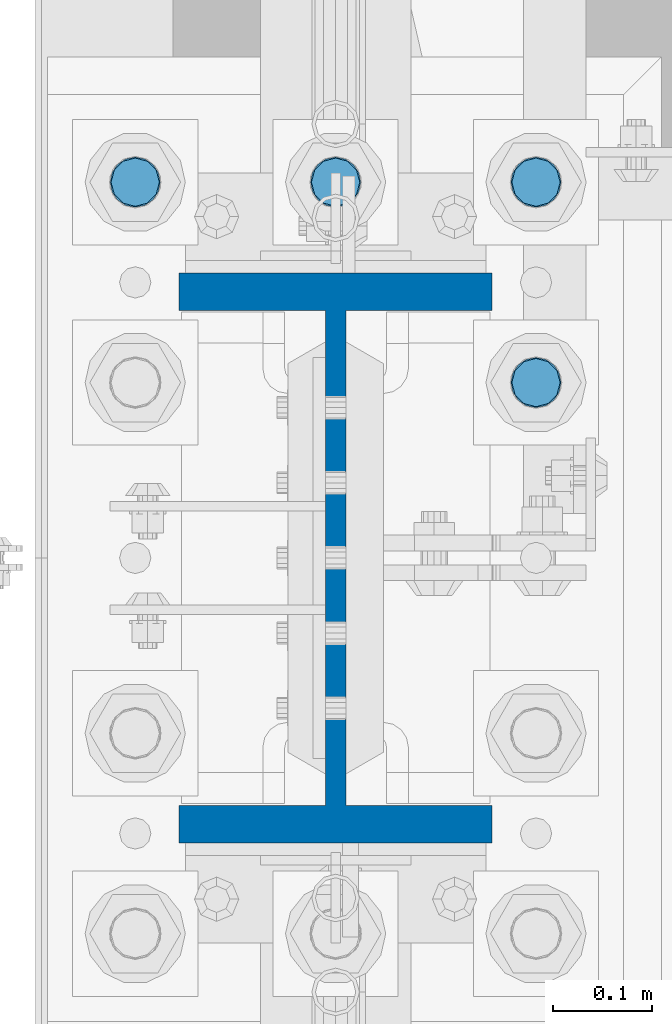
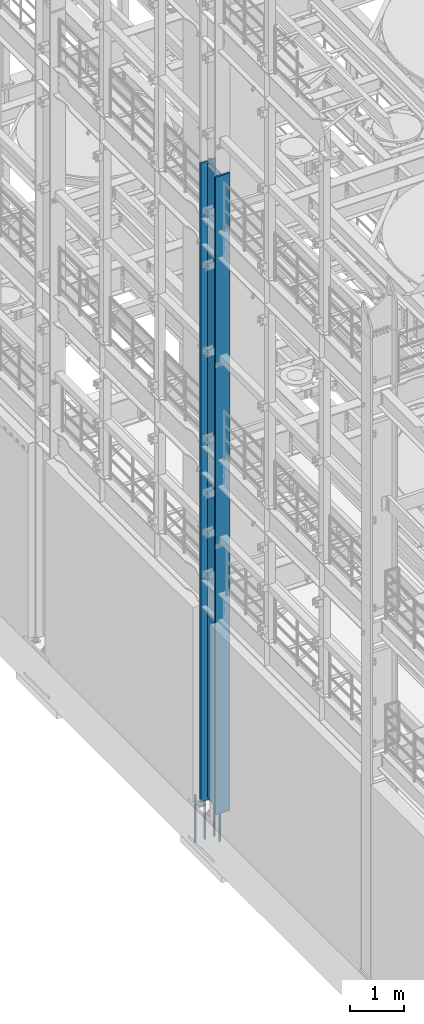
# One storey, part 688 of 1876: 5 columns, 2 elements without a shape of their own.
"""IFC2X3 building model written with IfcOpenShell, lengths in millimetres."""

from ifc_helpers import new_model, si_unit, frame, origin_with_axes, place, context, subcontext, project, spatial, faceted_brep, material, type_object, element, aggregate, save


model = new_model("IFC2X3")

# Units and contexts
model_context = context("Model", 3, precision=1e-05, world=origin_with_axes())
body_context = subcontext(model_context, "Body", "Model", "MODEL_VIEW")
ifc_project = project(units=[si_unit("LENGTHUNIT", "METRE", prefix="MILLI"), si_unit("AREAUNIT", "SQUARE_METRE"), si_unit("VOLUMEUNIT", "CUBIC_METRE"), si_unit("MASSUNIT", "GRAM", prefix="KILO"), si_unit("TIMEUNIT", "SECOND"), si_unit("PLANEANGLEUNIT", "RADIAN"), si_unit("SOLIDANGLEUNIT", "STERADIAN"), si_unit("THERMODYNAMICTEMPERATUREUNIT", "DEGREE_CELSIUS"), si_unit("LUMINOUSINTENSITYUNIT", "LUMEN")], contexts=[model_context])

# Site, building, storey
site_placement = place(None, origin_with_axes())
site = spatial("IfcSite", under=ifc_project, at=site_placement, CompositionType="ELEMENT")
building_placement = place(site_placement, origin_with_axes())
building = spatial("IfcBuilding", under=site, at=building_placement, Name="Undefined", CompositionType="ELEMENT")
storey_placement = place(building_placement, origin_with_axes())
storey = spatial("IfcBuildingStorey", under=building, at=storey_placement, Name="Undefined", CompositionType="ELEMENT", Elevation=0.0)

# Assembly, column
assembly_1_placement = place(storey_placement, origin_with_axes())
assembly_1 = element("IfcElementAssembly", 1, at=assembly_1_placement, inside=storey, Name="COLUMN", AssemblyPlace="NOTDEFINED", PredefinedType="RIGID_FRAME")
ifc_material_1 = material(Name="STEEL/A992")
column_type_1 = type_object("IfcColumnType", Name="W21X182", PredefinedType="NOTDEFINED")
column_1_placement = place(assembly_1_placement, frame((0.0, 1524.0, 0.0), z_axis=(0.0, 1.0, 0.0), x_axis=(0.0, 0.0, 1.0)))
column_1 = element("IfcColumn", 2, at=column_1_placement, type_object=column_type_1, material=ifc_material_1, Name="COLUMN", ObjectType="W21X182", context=body_context, shape_type="Brep", body=[
    faceted_brep([(115.887500412823, -10.3187499999967, 200.025000762939), (95.25, 10.31875, 200.025000762939), (95.25, 10.31875, -200.025000762939), (115.887500412823, -10.31875, -200.025000762939), (14528.8, -158.75, 288.925), (14528.8, 158.75, 288.925), (133.350000412822, 158.75, 288.925), (133.350000412824, -158.75, 288.925), (146.050000412824, -158.75, 250.825), (14478.0, -158.75, 250.825), (14528.8, -158.75, 250.825), (95.25, -158.75, 250.825), (146.050000412823, -10.3187500000004, 250.825), (14478.0, -10.3187500000004, 250.825), (14528.8, -10.3187500000004, 250.825), (95.25, -10.3187500000004, 250.825), (14528.8, -158.75, -288.925), (14528.8, -158.75, -250.825), (14478.0000007629, -158.75, -250.825), (146.050000412824, -158.75, -250.825), (95.25, -158.75, -250.825), (133.350000412824, -158.75, -288.925), (14528.8, 158.75, -288.925), (133.350000412822, 158.75, -288.925), (146.050000412824, 158.75, -250.825), (14478.0000007629, 158.75, -250.825), (14528.8, 158.75, -250.825), (95.25, 158.75, -250.825), (14528.8, 10.3187500000004, -250.825), (14528.8, -10.3187500000004, -250.825), (14478.0000007629, -10.3187500000004, -250.825), (146.050000412824, -10.3187500000004, -250.825), (95.25, -10.3187500000004, -250.825), (120.650000794293, -10.3187500000004, -200.025000762939), (120.650000794293, 10.3187500000004, -200.025000762939), (130.370159830384, 10.3187500000004, -201.958460608115), (130.370159830384, -10.3187500000004, -201.958460608115), (138.610512766692, 10.3187500000004, -207.464488409071), (138.610512766692, -10.3187500000004, -207.464488409071), (144.116540567648, 10.3187500000004, -215.704841345378), (144.116540567648, -10.3187500000004, -215.704841345378), (146.050000412823, 10.3187500000004, -225.42500038147), (146.050000412823, -10.3187500000004, -225.42500038147), (146.050000412824, 10.3187500000004, -250.825), (95.25, 10.3187500000004, -250.825), (14478.0000007629, 10.3187500000004, -250.825), (14481.8669204533, 10.3187500000004, -231.384681927818), (14481.8669204533, -10.3187500000004, -231.384681927818), (14492.8789760552, 10.3187500000004, -214.903976055203), (14492.8789760552, -10.3187500000004, -214.903976055203), (14509.3596819278, 10.3187500000004, -203.891920453291), (14509.3596819278, -10.3187500000004, -203.891920453291), (14528.8, -10.3187500000004, -200.025000762939), (14528.8, 10.3187500000004, -200.025000762939), (14528.8, 10.3187500000004, 200.025000762939), (14528.8, -10.3187500000004, 200.025000762939), (14509.3596811649, 10.3187500000004, 203.891920453291), (14509.3596811649, -10.3187500000004, 203.891920453291), (14492.8789752923, 10.3187500000004, 214.903976055203), (14492.8789752923, -10.3187500000004, 214.903976055203), (14481.8669196904, 10.3187500000004, 231.384681927818), (14481.8669196904, -10.3187500000004, 231.384681927818), (14478.0, 10.3187500000004, 250.825), (14528.8, 10.3187500000004, 250.825), (14528.8, 158.75, 250.825), (14478.0, 158.75, 250.825), (146.050000412824, 158.75, 250.825), (95.25, 158.75, 250.825), (95.25, 10.3187500000004, 250.825), (146.050000412824, 10.3187500000004, 250.825), (146.050000412823, 10.3187500000004, 225.42500038147), (146.050000412823, -10.3187500000004, 225.42500038147), (144.116540567648, 10.3187500000004, 215.704841345378), (144.116540567648, -10.3187500000004, 215.704841345378), (138.610512766692, 10.3187500000004, 207.464488409071), (138.610512766692, -10.3187500000004, 207.464488409071), (130.370159830384, 10.3187500000004, 201.958460608115), (130.370159830384, -10.3187500000004, 201.958460608115), (120.650000794293, 10.3187500000004, 200.025000762939), (120.650000794293, -10.3187500000004, 200.025000762939)], [[[0, 1, 2, 3]], [[4, 5, 6, 7]], [[8, 9, 10, 4, 7, 11]], [[12, 13, 14, 10, 9, 8, 11, 15]], [[16, 17, 18, 19, 20, 21]], [[22, 16, 21, 23]], [[24, 25, 26, 22, 23, 27]], [[17, 16, 22, 26, 28, 29]], [[19, 18, 17, 29, 30, 31, 32, 20]], [[33, 34, 35, 36]], [[36, 35, 37, 38]], [[38, 37, 39, 40]], [[40, 39, 41, 42]], [[42, 41, 43, 31]], [[31, 43, 44, 32]], [[27, 23, 21, 20, 32, 44]], [[43, 45, 28, 26, 25, 24, 27, 44]], [[29, 28, 45, 30]], [[30, 45, 46, 47]], [[47, 46, 48, 49]], [[49, 48, 50, 51]], [[52, 51, 50, 53]], [[54, 55, 52, 53]], [[55, 54, 56, 57]], [[57, 56, 58, 59]], [[59, 58, 60, 61]], [[61, 60, 62, 13]], [[14, 13, 62, 63]], [[64, 5, 4, 10, 14, 63]], [[5, 64, 65, 66, 67, 6]], [[11, 7, 6, 67, 68, 15]], [[66, 65, 64, 63, 62, 69, 68, 67]], [[15, 68, 69, 12]], [[12, 69, 70, 71]], [[71, 70, 72, 73]], [[73, 72, 74, 75]], [[75, 74, 76, 77]], [[77, 76, 78, 79]], [[33, 36, 38, 40, 42, 31, 30, 47, 49, 51, 52, 55, 57, 59, 61, 13, 12, 71, 73, 75, 77, 79, 0, 3]], [[34, 33, 3, 2]], [[78, 76, 74, 72, 70, 69, 62, 60, 58, 56, 54, 53, 50, 48, 46, 45, 43, 41, 39, 37, 35, 34, 2, 1]], [[79, 78, 1, 0]]]),
])
aggregate(assembly_1, [column_1])

# Assembly, columns
assembly_2_placement = place(storey_placement, origin_with_axes())
assembly_2 = element("IfcElementAssembly", 3, at=assembly_2_placement, inside=storey, Name="TEMPLATE", AssemblyPlace="NOTDEFINED", PredefinedType="RIGID_FRAME")
ifc_material_2 = material(Name="STEEL/F1554-GR.105")
column_type_2 = type_object("IfcColumnType", PredefinedType="NOTDEFINED")
column_2_placement = place(assembly_2_placement, frame((203.2, 1701.8, 0.0), z_axis=(0.0, 1.0, 0.0), x_axis=(0.0, 0.0, -1.0)))
column_2 = element("IfcColumn", 4, at=column_2_placement, type_object=column_type_2, material=ifc_material_2, Name="ANCHOR_BOLTS", context=body_context, shape_type="Brep", body=[
    faceted_brep([(-196.85, -21.217622392719, 12.25), (-196.85, -12.25, 21.2176223927188), (-196.85, 0.0, 24.5), (-196.85, 12.25, 21.2176223927188), (-196.85, 21.217622392719, 12.25), (-196.85, 24.5, 0.0), (-196.85, 21.217622392719, -12.25), (-196.85, 12.25, -21.2176223927188), (-196.85, 0.0, -24.5), (-196.85, -12.25, -21.2176223927188), (-196.85, -21.217622392719, -12.25), (-196.85, -24.5, 0.0), (0.0, 24.5, 0.0), (0.0, 21.217622392719, -12.25), (0.0, 12.25, -21.2176223927188), (0.0, 0.0, -24.5), (0.0, -12.25, -21.2176223927188), (0.0, -21.217622392719, -12.25), (0.0, -24.5, 0.0), (0.0, -21.217622392719, 12.25), (0.0, -12.25, 21.2176223927188), (0.0, 0.0, 24.5), (0.0, 12.25, 21.2176223927188), (0.0, 21.217622392719, 12.25), (0.0, -23.4665401257871, 9.7201591820733), (0.0, -17.9605122421381, 17.9605122421383), (0.0, -9.72015918207308, 23.4665401257867), (0.0, 0.0, 25.4000000000001), (0.0, 9.72015918207308, 23.4665401257867), (0.0, 17.9605122421381, 17.9605122421383), (0.0, 23.4665401257871, 9.7201591820733), (0.0, 25.3999996185339, 9.09494701772928e-13), (0.0, 23.4665401257871, -9.7201591820733), (0.0, 17.9605122421381, -17.9605122421383), (0.0, 9.72015918207308, -23.4665401257867), (0.0, 0.0, -25.4000000000001), (0.0, -9.72015918207308, -23.4665401257867), (0.0, -17.9605122421381, -17.9605122421383), (0.0, -23.4665401257871, -9.7201591820733), (0.0, -25.3999996185375, 0.0), (673.1, -25.3999999999996, 0.0), (673.1, -23.4665401257871, 9.7201591820733), (673.1, -17.9605122421381, 17.9605122421383), (673.1, -9.72015918207308, 23.4665401257867), (673.1, 0.0, 25.4000000000001), (673.1, 9.72015918207308, 23.4665401257867), (673.1, 17.9605122421381, 17.9605122421383), (673.1, 23.4665401257871, 9.7201591820733), (673.1, 25.3999999999996, 0.0), (673.1, 23.4665401257871, -9.7201591820733), (673.1, 17.9605122421381, -17.9605122421383), (673.1, 9.72015918207308, -23.4665401257867), (673.1, 0.0, -25.4000000000001), (673.1, -9.72015918207308, -23.4665401257867), (673.1, -17.9605122421381, -17.9605122421383), (673.1, -23.4665401257871, -9.7201591820733), (673.1, -12.25, 21.2176223927188), (673.1, 0.0, 24.5), (673.1, 12.25, 21.2176223927188), (673.1, 21.217622392719, 12.25), (673.1, 24.5, 0.0), (673.1, 21.217622392719, -12.25), (673.1, 12.25, -21.2176223927188), (673.1, 0.0, -24.5), (673.1, -12.25, -21.2176223927188), (673.1, -21.217622392719, -12.25), (673.1, -24.5, 0.0), (673.1, -21.217622392719, 12.25), (869.95, -12.25, -21.2176223927188), (869.95, 0.0, -24.5), (869.95, 12.25, -21.2176223927188), (869.95, 21.217622392719, -12.25), (869.95, 24.5, 0.0), (869.95, 21.217622392719, 12.25), (869.95, 12.25, 21.2176223927188), (869.95, 0.0, 24.5), (869.95, -12.25, 21.2176223927188), (869.95, -21.217622392719, 12.25), (869.95, -24.5, 0.0), (869.95, -21.217622392719, -12.25)], [[[0, 1, 2, 3, 4, 5, 6, 7, 8, 9, 10, 11]], [[6, 5, 12, 13]], [[7, 6, 13, 14]], [[8, 7, 14, 15]], [[9, 8, 15, 16]], [[10, 9, 16, 17]], [[11, 10, 17, 18]], [[0, 11, 18, 19]], [[1, 0, 19, 20]], [[2, 1, 20, 21]], [[3, 2, 21, 22]], [[4, 3, 22, 23]], [[5, 4, 23, 12]], [[24, 25, 26, 27, 28, 29, 30, 31, 32, 33, 34, 35, 36, 37, 38, 39], [22, 21, 20, 19, 18, 17, 16, 15, 14, 13, 12, 23]], [[24, 39, 40, 41]], [[25, 24, 41, 42]], [[26, 25, 42, 43]], [[27, 26, 43, 44]], [[28, 27, 44, 45]], [[29, 28, 45, 46]], [[30, 29, 46, 47]], [[31, 30, 47, 48]], [[32, 31, 48, 49]], [[33, 32, 49, 50]], [[34, 33, 50, 51]], [[35, 34, 51, 52]], [[36, 35, 52, 53]], [[37, 36, 53, 54]], [[38, 37, 54, 55]], [[39, 38, 55, 40]], [[54, 53, 52, 51, 50, 49, 48, 47, 46, 45, 44, 43, 42, 41, 40, 55], [56, 57, 58, 59, 60, 61, 62, 63, 64, 65, 66, 67]], [[68, 69, 70, 71, 72, 73, 74, 75, 76, 77, 78, 79]], [[76, 75, 57, 56]], [[77, 76, 56, 67]], [[78, 77, 67, 66]], [[79, 78, 66, 65]], [[68, 79, 65, 64]], [[69, 68, 64, 63]], [[70, 69, 63, 62]], [[71, 70, 62, 61]], [[72, 71, 61, 60]], [[73, 72, 60, 59]], [[74, 73, 59, 58]], [[75, 74, 58, 57]]]),
])
column_3_placement = place(assembly_2_placement, frame((-203.2, 1905.0, 0.0), z_axis=(0.0, -1.0, 0.0), x_axis=(0.0, 0.0, -1.0)))
column_3 = element("IfcColumn", 5, at=column_3_placement, type_object=column_type_2, material=ifc_material_2, Name="ANCHOR_BOLTS", context=body_context, shape_type="Brep", body=[
    faceted_brep([(-196.85, -21.217622392719, 12.25), (-196.85, -12.25, 21.2176223927188), (-196.85, 0.0, 24.5), (-196.85, 12.25, 21.2176223927188), (-196.85, 21.217622392719, 12.25), (-196.85, 24.5, 0.0), (-196.85, 21.217622392719, -12.25), (-196.85, 12.25, -21.2176223927188), (-196.85, 0.0, -24.5), (-196.85, -12.25, -21.2176223927188), (-196.85, -21.217622392719, -12.25), (-196.85, -24.5, 0.0), (0.0, 24.5, 0.0), (0.0, 21.217622392719, -12.25), (0.0, 12.25, -21.2176223927188), (0.0, 0.0, -24.5), (0.0, -12.25, -21.2176223927188), (0.0, -21.217622392719, -12.25), (0.0, -24.5, 0.0), (0.0, -21.217622392719, 12.25), (0.0, -12.25, 21.2176223927188), (0.0, 0.0, 24.5), (0.0, 12.25, 21.2176223927188), (0.0, 21.217622392719, 12.25), (0.0, -23.4665401257871, 9.7201591820733), (0.0, -17.9605122421381, 17.9605122421383), (0.0, -9.72015918207308, 23.4665401257867), (0.0, 0.0, 25.4000000000001), (0.0, 9.72015918207308, 23.4665401257867), (0.0, 17.9605122421381, 17.9605122421383), (0.0, 23.4665401257871, 9.7201591820733), (0.0, 25.3999996185339, 9.09494701772928e-13), (0.0, 23.4665401257871, -9.7201591820733), (0.0, 17.9605122421381, -17.9605122421383), (0.0, 9.72015918207308, -23.4665401257867), (0.0, 0.0, -25.4000000000001), (0.0, -9.72015918207308, -23.4665401257867), (0.0, -17.9605122421381, -17.9605122421383), (0.0, -23.4665401257871, -9.7201591820733), (0.0, -25.3999996185375, 0.0), (673.1, -25.3999999999996, 0.0), (673.1, -23.4665401257871, 9.7201591820733), (673.1, -17.9605122421381, 17.9605122421383), (673.1, -9.72015918207308, 23.4665401257867), (673.1, 0.0, 25.4000000000001), (673.1, 9.72015918207308, 23.4665401257867), (673.1, 17.9605122421381, 17.9605122421383), (673.1, 23.4665401257871, 9.7201591820733), (673.1, 25.3999999999996, 0.0), (673.1, 23.4665401257871, -9.7201591820733), (673.1, 17.9605122421381, -17.9605122421383), (673.1, 9.72015918207308, -23.4665401257867), (673.1, 0.0, -25.4000000000001), (673.1, -9.72015918207308, -23.4665401257867), (673.1, -17.9605122421381, -17.9605122421383), (673.1, -23.4665401257871, -9.7201591820733), (673.1, -12.25, 21.2176223927188), (673.1, 0.0, 24.5), (673.1, 12.25, 21.2176223927188), (673.1, 21.217622392719, 12.25), (673.1, 24.5, 0.0), (673.1, 21.217622392719, -12.25), (673.1, 12.25, -21.2176223927188), (673.1, 0.0, -24.5), (673.1, -12.25, -21.2176223927188), (673.1, -21.217622392719, -12.25), (673.1, -24.5, 0.0), (673.1, -21.217622392719, 12.25), (869.95, -12.25, -21.2176223927188), (869.95, 0.0, -24.5), (869.95, 12.25, -21.2176223927188), (869.95, 21.217622392719, -12.25), (869.95, 24.5, 0.0), (869.95, 21.217622392719, 12.25), (869.95, 12.25, 21.2176223927188), (869.95, 0.0, 24.5), (869.95, -12.25, 21.2176223927188), (869.95, -21.217622392719, 12.25), (869.95, -24.5, 0.0), (869.95, -21.217622392719, -12.25)], [[[0, 1, 2, 3, 4, 5, 6, 7, 8, 9, 10, 11]], [[6, 5, 12, 13]], [[7, 6, 13, 14]], [[8, 7, 14, 15]], [[9, 8, 15, 16]], [[10, 9, 16, 17]], [[11, 10, 17, 18]], [[0, 11, 18, 19]], [[1, 0, 19, 20]], [[2, 1, 20, 21]], [[3, 2, 21, 22]], [[4, 3, 22, 23]], [[5, 4, 23, 12]], [[24, 25, 26, 27, 28, 29, 30, 31, 32, 33, 34, 35, 36, 37, 38, 39], [22, 21, 20, 19, 18, 17, 16, 15, 14, 13, 12, 23]], [[24, 39, 40, 41]], [[25, 24, 41, 42]], [[26, 25, 42, 43]], [[27, 26, 43, 44]], [[28, 27, 44, 45]], [[29, 28, 45, 46]], [[30, 29, 46, 47]], [[31, 30, 47, 48]], [[32, 31, 48, 49]], [[33, 32, 49, 50]], [[34, 33, 50, 51]], [[35, 34, 51, 52]], [[36, 35, 52, 53]], [[37, 36, 53, 54]], [[38, 37, 54, 55]], [[39, 38, 55, 40]], [[54, 53, 52, 51, 50, 49, 48, 47, 46, 45, 44, 43, 42, 41, 40, 55], [56, 57, 58, 59, 60, 61, 62, 63, 64, 65, 66, 67]], [[68, 69, 70, 71, 72, 73, 74, 75, 76, 77, 78, 79]], [[76, 75, 57, 56]], [[77, 76, 56, 67]], [[78, 77, 67, 66]], [[79, 78, 66, 65]], [[68, 79, 65, 64]], [[69, 68, 64, 63]], [[70, 69, 63, 62]], [[71, 70, 62, 61]], [[72, 71, 61, 60]], [[73, 72, 60, 59]], [[74, 73, 59, 58]], [[75, 74, 58, 57]]]),
])
column_4_placement = place(assembly_2_placement, frame((0.0, 1905.0, 0.0), z_axis=(0.0, -1.0, 0.0), x_axis=(0.0, 0.0, -1.0)))
column_4 = element("IfcColumn", 6, at=column_4_placement, type_object=column_type_2, material=ifc_material_2, Name="ANCHOR_BOLTS", context=body_context, shape_type="Brep", body=[
    faceted_brep([(-196.85, -21.217622392719, 12.25), (-196.85, -12.25, 21.2176223927188), (-196.85, 0.0, 24.5), (-196.85, 12.25, 21.2176223927188), (-196.85, 21.217622392719, 12.25), (-196.85, 24.5, 0.0), (-196.85, 21.217622392719, -12.25), (-196.85, 12.25, -21.2176223927188), (-196.85, 0.0, -24.5), (-196.85, -12.25, -21.2176223927188), (-196.85, -21.217622392719, -12.25), (-196.85, -24.5, 0.0), (0.0, 24.5, 0.0), (0.0, 21.217622392719, -12.25), (0.0, 12.25, -21.2176223927188), (0.0, 0.0, -24.5), (0.0, -12.25, -21.2176223927188), (0.0, -21.217622392719, -12.25), (0.0, -24.5, 0.0), (0.0, -21.217622392719, 12.25), (0.0, -12.25, 21.2176223927188), (0.0, 0.0, 24.5), (0.0, 12.25, 21.2176223927188), (0.0, 21.217622392719, 12.25), (0.0, -23.4665401257871, 9.7201591820733), (0.0, -17.9605122421381, 17.9605122421383), (0.0, -9.72015918207308, 23.4665401257867), (0.0, 0.0, 25.4000000000001), (0.0, 9.72015918207308, 23.4665401257867), (0.0, 17.9605122421381, 17.9605122421383), (0.0, 23.4665401257871, 9.7201591820733), (0.0, 25.3999996185339, 9.09494701772928e-13), (0.0, 23.4665401257871, -9.7201591820733), (0.0, 17.9605122421381, -17.9605122421383), (0.0, 9.72015918207308, -23.4665401257867), (0.0, 0.0, -25.4000000000001), (0.0, -9.72015918207308, -23.4665401257867), (0.0, -17.9605122421381, -17.9605122421383), (0.0, -23.4665401257871, -9.7201591820733), (0.0, -25.3999996185375, 0.0), (673.1, -25.3999999999996, 0.0), (673.1, -23.4665401257871, 9.7201591820733), (673.1, -17.9605122421381, 17.9605122421383), (673.1, -9.72015918207308, 23.4665401257867), (673.1, 0.0, 25.4000000000001), (673.1, 9.72015918207308, 23.4665401257867), (673.1, 17.9605122421381, 17.9605122421383), (673.1, 23.4665401257871, 9.7201591820733), (673.1, 25.3999999999996, 0.0), (673.1, 23.4665401257871, -9.7201591820733), (673.1, 17.9605122421381, -17.9605122421383), (673.1, 9.72015918207308, -23.4665401257867), (673.1, 0.0, -25.4000000000001), (673.1, -9.72015918207308, -23.4665401257867), (673.1, -17.9605122421381, -17.9605122421383), (673.1, -23.4665401257871, -9.7201591820733), (673.1, -12.25, 21.2176223927188), (673.1, 0.0, 24.5), (673.1, 12.25, 21.2176223927188), (673.1, 21.217622392719, 12.25), (673.1, 24.5, 0.0), (673.1, 21.217622392719, -12.25), (673.1, 12.25, -21.2176223927188), (673.1, 0.0, -24.5), (673.1, -12.25, -21.2176223927188), (673.1, -21.217622392719, -12.25), (673.1, -24.5, 0.0), (673.1, -21.217622392719, 12.25), (869.95, -12.25, -21.2176223927188), (869.95, 0.0, -24.5), (869.95, 12.25, -21.2176223927188), (869.95, 21.217622392719, -12.25), (869.95, 24.5, 0.0), (869.95, 21.217622392719, 12.25), (869.95, 12.25, 21.2176223927188), (869.95, 0.0, 24.5), (869.95, -12.25, 21.2176223927188), (869.95, -21.217622392719, 12.25), (869.95, -24.5, 0.0), (869.95, -21.217622392719, -12.25)], [[[0, 1, 2, 3, 4, 5, 6, 7, 8, 9, 10, 11]], [[6, 5, 12, 13]], [[7, 6, 13, 14]], [[8, 7, 14, 15]], [[9, 8, 15, 16]], [[10, 9, 16, 17]], [[11, 10, 17, 18]], [[0, 11, 18, 19]], [[1, 0, 19, 20]], [[2, 1, 20, 21]], [[3, 2, 21, 22]], [[4, 3, 22, 23]], [[5, 4, 23, 12]], [[24, 25, 26, 27, 28, 29, 30, 31, 32, 33, 34, 35, 36, 37, 38, 39], [22, 21, 20, 19, 18, 17, 16, 15, 14, 13, 12, 23]], [[24, 39, 40, 41]], [[25, 24, 41, 42]], [[26, 25, 42, 43]], [[27, 26, 43, 44]], [[28, 27, 44, 45]], [[29, 28, 45, 46]], [[30, 29, 46, 47]], [[31, 30, 47, 48]], [[32, 31, 48, 49]], [[33, 32, 49, 50]], [[34, 33, 50, 51]], [[35, 34, 51, 52]], [[36, 35, 52, 53]], [[37, 36, 53, 54]], [[38, 37, 54, 55]], [[39, 38, 55, 40]], [[54, 53, 52, 51, 50, 49, 48, 47, 46, 45, 44, 43, 42, 41, 40, 55], [56, 57, 58, 59, 60, 61, 62, 63, 64, 65, 66, 67]], [[68, 69, 70, 71, 72, 73, 74, 75, 76, 77, 78, 79]], [[76, 75, 57, 56]], [[77, 76, 56, 67]], [[78, 77, 67, 66]], [[79, 78, 66, 65]], [[68, 79, 65, 64]], [[69, 68, 64, 63]], [[70, 69, 63, 62]], [[71, 70, 62, 61]], [[72, 71, 61, 60]], [[73, 72, 60, 59]], [[74, 73, 59, 58]], [[75, 74, 58, 57]]]),
])
column_5_placement = place(assembly_2_placement, frame((203.2, 1905.0, 0.0), z_axis=(0.0, 1.0, 0.0), x_axis=(0.0, 0.0, -1.0)))
column_5 = element("IfcColumn", 7, at=column_5_placement, type_object=column_type_2, material=ifc_material_2, Name="ANCHOR_BOLTS", context=body_context, shape_type="Brep", body=[
    faceted_brep([(-196.85, -21.217622392719, 12.25), (-196.85, -12.25, 21.2176223927188), (-196.85, 0.0, 24.5), (-196.85, 12.25, 21.2176223927188), (-196.85, 21.217622392719, 12.25), (-196.85, 24.5, 0.0), (-196.85, 21.217622392719, -12.25), (-196.85, 12.25, -21.2176223927188), (-196.85, 0.0, -24.5), (-196.85, -12.25, -21.2176223927188), (-196.85, -21.217622392719, -12.25), (-196.85, -24.5, 0.0), (0.0, 24.5, 0.0), (0.0, 21.217622392719, -12.25), (0.0, 12.25, -21.2176223927188), (0.0, 0.0, -24.5), (0.0, -12.25, -21.2176223927188), (0.0, -21.217622392719, -12.25), (0.0, -24.5, 0.0), (0.0, -21.217622392719, 12.25), (0.0, -12.25, 21.2176223927188), (0.0, 0.0, 24.5), (0.0, 12.25, 21.2176223927188), (0.0, 21.217622392719, 12.25), (0.0, -23.4665401257871, 9.7201591820733), (0.0, -17.9605122421381, 17.9605122421383), (0.0, -9.72015918207308, 23.4665401257867), (0.0, 0.0, 25.4000000000001), (0.0, 9.72015918207308, 23.4665401257867), (0.0, 17.9605122421381, 17.9605122421383), (0.0, 23.4665401257871, 9.7201591820733), (0.0, 25.3999996185339, 9.09494701772928e-13), (0.0, 23.4665401257871, -9.7201591820733), (0.0, 17.9605122421381, -17.9605122421383), (0.0, 9.72015918207308, -23.4665401257867), (0.0, 0.0, -25.4000000000001), (0.0, -9.72015918207308, -23.4665401257867), (0.0, -17.9605122421381, -17.9605122421383), (0.0, -23.4665401257871, -9.7201591820733), (0.0, -25.3999996185375, 0.0), (673.1, -25.3999999999996, 0.0), (673.1, -23.4665401257871, 9.7201591820733), (673.1, -17.9605122421381, 17.9605122421383), (673.1, -9.72015918207308, 23.4665401257867), (673.1, 0.0, 25.4000000000001), (673.1, 9.72015918207308, 23.4665401257867), (673.1, 17.9605122421381, 17.9605122421383), (673.1, 23.4665401257871, 9.7201591820733), (673.1, 25.3999999999996, 0.0), (673.1, 23.4665401257871, -9.7201591820733), (673.1, 17.9605122421381, -17.9605122421383), (673.1, 9.72015918207308, -23.4665401257867), (673.1, 0.0, -25.4000000000001), (673.1, -9.72015918207308, -23.4665401257867), (673.1, -17.9605122421381, -17.9605122421383), (673.1, -23.4665401257871, -9.7201591820733), (673.1, -12.25, 21.2176223927188), (673.1, 0.0, 24.5), (673.1, 12.25, 21.2176223927188), (673.1, 21.217622392719, 12.25), (673.1, 24.5, 0.0), (673.1, 21.217622392719, -12.25), (673.1, 12.25, -21.2176223927188), (673.1, 0.0, -24.5), (673.1, -12.25, -21.2176223927188), (673.1, -21.217622392719, -12.25), (673.1, -24.5, 0.0), (673.1, -21.217622392719, 12.25), (869.95, -12.25, -21.2176223927188), (869.95, 0.0, -24.5), (869.95, 12.25, -21.2176223927188), (869.95, 21.217622392719, -12.25), (869.95, 24.5, 0.0), (869.95, 21.217622392719, 12.25), (869.95, 12.25, 21.2176223927188), (869.95, 0.0, 24.5), (869.95, -12.25, 21.2176223927188), (869.95, -21.217622392719, 12.25), (869.95, -24.5, 0.0), (869.95, -21.217622392719, -12.25)], [[[0, 1, 2, 3, 4, 5, 6, 7, 8, 9, 10, 11]], [[6, 5, 12, 13]], [[7, 6, 13, 14]], [[8, 7, 14, 15]], [[9, 8, 15, 16]], [[10, 9, 16, 17]], [[11, 10, 17, 18]], [[0, 11, 18, 19]], [[1, 0, 19, 20]], [[2, 1, 20, 21]], [[3, 2, 21, 22]], [[4, 3, 22, 23]], [[5, 4, 23, 12]], [[24, 25, 26, 27, 28, 29, 30, 31, 32, 33, 34, 35, 36, 37, 38, 39], [22, 21, 20, 19, 18, 17, 16, 15, 14, 13, 12, 23]], [[24, 39, 40, 41]], [[25, 24, 41, 42]], [[26, 25, 42, 43]], [[27, 26, 43, 44]], [[28, 27, 44, 45]], [[29, 28, 45, 46]], [[30, 29, 46, 47]], [[31, 30, 47, 48]], [[32, 31, 48, 49]], [[33, 32, 49, 50]], [[34, 33, 50, 51]], [[35, 34, 51, 52]], [[36, 35, 52, 53]], [[37, 36, 53, 54]], [[38, 37, 54, 55]], [[39, 38, 55, 40]], [[54, 53, 52, 51, 50, 49, 48, 47, 46, 45, 44, 43, 42, 41, 40, 55], [56, 57, 58, 59, 60, 61, 62, 63, 64, 65, 66, 67]], [[68, 69, 70, 71, 72, 73, 74, 75, 76, 77, 78, 79]], [[76, 75, 57, 56]], [[77, 76, 56, 67]], [[78, 77, 67, 66]], [[79, 78, 66, 65]], [[68, 79, 65, 64]], [[69, 68, 64, 63]], [[70, 69, 63, 62]], [[71, 70, 62, 61]], [[72, 71, 61, 60]], [[73, 72, 60, 59]], [[74, 73, 59, 58]], [[75, 74, 58, 57]]]),
])
aggregate(assembly_2, [column_2, column_3, column_4, column_5])

save(model, "model.ifc")
